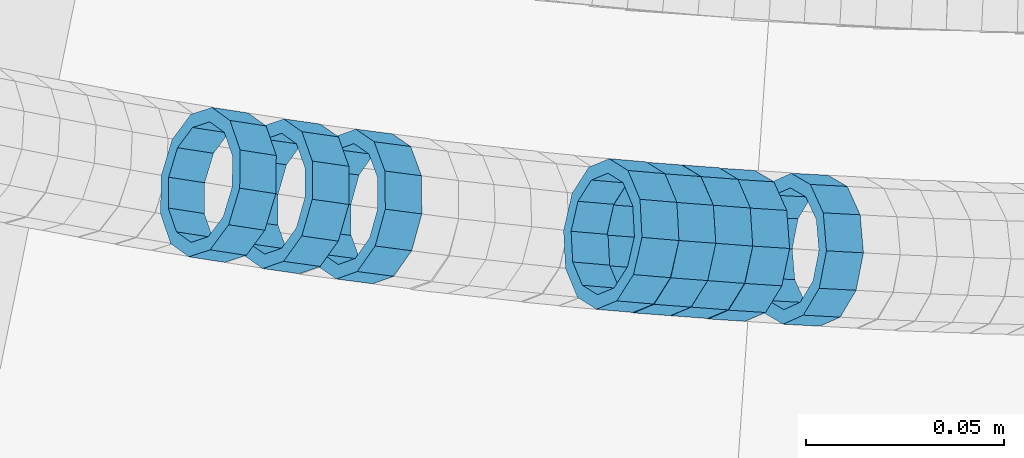
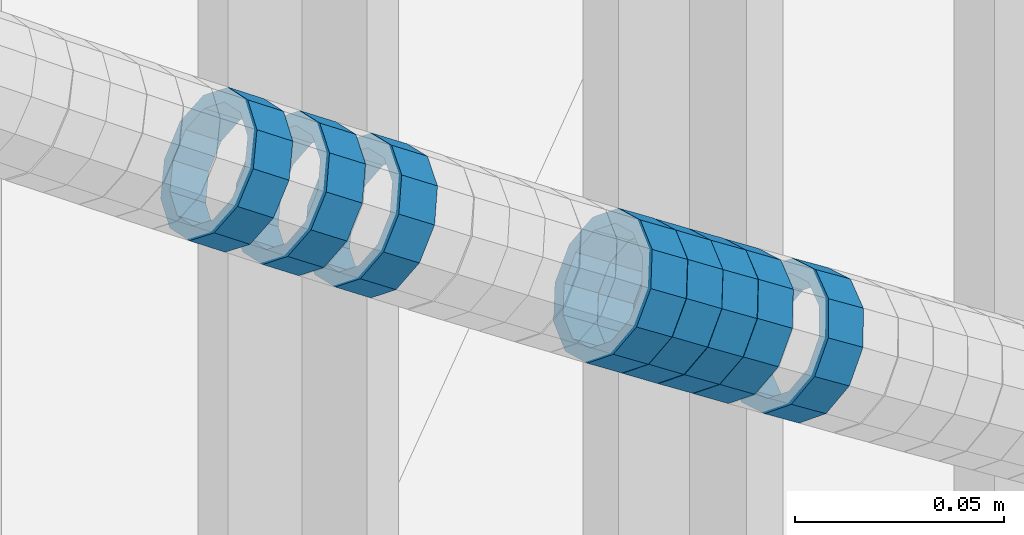
# One storey, part 684 of 975: 8 members.
"""IFC2X3 building model written with IfcOpenShell, lengths in millimetres."""

from ifc_helpers import new_model, si_unit, frame, origin_with_axes, place, context, subcontext, project, spatial, faceted_brep, material, type_object, element, save


model = new_model("IFC2X3")

# Units and contexts
model_context = context("Model", 3, precision=1e-05, world=origin_with_axes())
body_context = subcontext(model_context, "Body", "Model", "MODEL_VIEW")
ifc_project = project(units=[si_unit("LENGTHUNIT", "METRE", prefix="MILLI"), si_unit("AREAUNIT", "SQUARE_METRE"), si_unit("VOLUMEUNIT", "CUBIC_METRE"), si_unit("MASSUNIT", "GRAM", prefix="KILO"), si_unit("TIMEUNIT", "SECOND"), si_unit("PLANEANGLEUNIT", "RADIAN"), si_unit("SOLIDANGLEUNIT", "STERADIAN"), si_unit("THERMODYNAMICTEMPERATUREUNIT", "DEGREE_CELSIUS"), si_unit("LUMINOUSINTENSITYUNIT", "LUMEN")], contexts=[model_context])

# Site, building, storey
site_placement = place(None, origin_with_axes())
site = spatial("IfcSite", under=ifc_project, at=site_placement, CompositionType="ELEMENT")
building_placement = place(site_placement, origin_with_axes())
building = spatial("IfcBuilding", under=site, at=building_placement, Name="Undefined", CompositionType="ELEMENT")
storey_placement = place(building_placement, origin_with_axes())
storey = spatial("IfcBuildingStorey", under=building, at=storey_placement, Name="Undefined", CompositionType="ELEMENT", Elevation=0.0)

# Members
ifc_material = material()
member_type = type_object("IfcMemberType", PredefinedType="NOTDEFINED")
member_1_placement = place(storey_placement, frame((34649.9665897505, 1926.44126368959, 4259.15155085601), z_axis=(-0.0536859073060332, -0.998557871811508, 1.96610926650465e-10), x_axis=(-0.85170692112707, 0.0457906950068331, 0.522013920077845)))
element("IfcMember", 1, at=member_1_placement, inside=storey, type_object=member_type, material=ifc_material, Name="WALL", context=body_context, shape_type="Brep", body=[
    faceted_brep([(-2.1246523829177e-07, -15.367000000002, 0.0), (-1.83998054126278e-07, -13.3082123799541, 7.68350000000009), (10.9242848735521, -13.3082123800159, 7.68350000000919), (10.9242848735703, -15.3670000000457, 6.82121026329696e-12), (-1.06232619145885e-07, -7.68349999999919, 13.3082123799559), (10.9242848735521, -7.68350000005739, 13.3082123799652), (-3.63797880709171e-12, 3.63797880709171e-12, 15.3670000000002), (10.924284873563, -4.72937244921923e-11, 15.3670000000088), (1.06225343188271e-07, 7.68350000000646, 13.3082123799559), (10.9242848735885, 7.68349999997008, 13.308212379962), (1.8399441614747e-07, 13.308212379965, 7.68350000000009), (10.9242848736176, 13.3082123799468, 7.68350000000328), (2.12461600312963e-07, 15.3670000000093, 0.0), (10.9242848736394, 15.3670000000093, 0.0), (1.8399441614747e-07, 13.308212379965, -7.68350000000009), (10.9242848736576, 13.3082123799795, -7.6835000000026), (1.06225343188271e-07, 7.68350000000646, -13.3082123799559), (10.9242848736576, 7.68350000002465, -13.3082123799584), (-3.63797880709171e-12, 3.63797880709171e-12, -15.3670000000002), (10.9242848736467, 1.45519152283669e-11, -15.3670000000025), (-1.06232619145885e-07, -7.68349999999919, -13.3082123799559), (10.9242848736212, -7.68350000000282, -13.3082123799552), (-1.83998054126278e-07, -13.3082123799541, -7.68350000000009), (10.9242848735958, -13.3082123799832, -7.68349999999646), (-2.63386027654633e-07, -19.0500000000029, 0.0), (-2.28097633225843e-07, -16.4977839420972, -9.52499999999964), (10.9242848735885, -16.4977839421226, -9.52499999999577), (10.9242848735557, -19.0500000000575, 8.18545231595635e-12), (-1.31691194837913e-07, -9.52500000000146, -16.4977839420935), (10.9242848736249, -9.52500000000146, -16.4977839420942), (-3.63797880709171e-12, 3.63797880709171e-12, -19.0500000000002), (10.924284873654, 2.18278728425503e-11, -19.0500000000038), (1.31687556859106e-07, 9.52500000000509, -16.4977839420935), (10.9242848736758, 9.52500000003783, -16.4977839420985), (2.28097633225843e-07, 16.4977839421044, -9.52499999999964), (10.9242848736758, 16.4977839421299, -9.52500000000418), (2.63382389675826e-07, 19.0500000000138, 0.0), (10.9242848736503, 19.0500000000211, -1.36424205265939e-12), (2.28097633225843e-07, 16.4977839421044, 9.52499999999964), (10.9242848736249, 16.4977839420899, 9.52500000000259), (1.31687556859106e-07, 9.52500000000509, 16.4977839420935), (10.9242848735885, 9.52499999996508, 16.4977839421008), (-3.63797880709171e-12, 3.63797880709171e-12, 19.0500000000002), (10.9242848735594, -5.82076609134674e-11, 19.0500000000104), (-1.31691194837913e-07, -9.52500000000146, 16.4977839420935), (10.9242848735375, -9.52500000007058, 16.4977839421056), (-2.28097633225843e-07, -16.4977839420972, 9.52499999999964), (10.9242848735412, -16.4977839421626, 9.52500000001078)], [[[0, 1, 2, 3]], [[1, 4, 5, 2]], [[4, 6, 7, 5]], [[6, 8, 9, 7]], [[8, 10, 11, 9]], [[10, 12, 13, 11]], [[12, 14, 15, 13]], [[14, 16, 17, 15]], [[16, 18, 19, 17]], [[18, 20, 21, 19]], [[20, 22, 23, 21]], [[22, 0, 3, 23]], [[24, 25, 26, 27]], [[25, 28, 29, 26]], [[28, 30, 31, 29]], [[30, 32, 33, 31]], [[32, 34, 35, 33]], [[34, 36, 37, 35]], [[36, 38, 39, 37]], [[38, 40, 41, 39]], [[40, 42, 43, 41]], [[42, 44, 45, 43]], [[44, 46, 47, 45]], [[46, 24, 27, 47]], [[29, 31, 33, 35, 37, 39, 41, 43, 45, 47, 27, 26], [5, 7, 9, 11, 13, 15, 17, 19, 21, 23, 3, 2]], [[46, 44, 42, 40, 38, 36, 34, 32, 30, 28, 25, 24], [22, 20, 18, 16, 14, 12, 10, 8, 6, 4, 1, 0]]]),
])
member_2_placement = place(storey_placement, frame((34631.2517163912, 1927.65544932693, 4270.62648604053), z_axis=(-0.0643822783268261, -0.997925308947241, 2.01563125301618e-10), x_axis=(-0.847241940782439, 0.0546607699859694, 0.528387446864275)))
element("IfcMember", 2, at=member_2_placement, inside=storey, type_object=member_type, material=ifc_material, Name="WALL", context=body_context, shape_type="Brep", body=[
    faceted_brep([(-2.1246523829177e-07, -15.367000000002, 0.0), (-1.83998054126278e-07, -13.3082123799541, 7.68350000000009), (10.9799817850508, -13.3082123799686, 7.6835000000051), (10.9799817850435, -15.3670000000202, 5.45696821063757e-12), (-1.06232619145885e-07, -7.68349999999919, 13.3082123799559), (10.9799817850653, -7.68350000000282, 13.3082123799577), (-3.63797880709171e-12, 3.63797880709171e-12, 15.3670000000002), (10.9799817850871, 1.45519152283669e-11, 15.3669999999984), (1.06225343188271e-07, 7.68350000000646, 13.3082123799559), (10.9799817851053, 7.68350000002465, 13.3082123799504), (1.8399441614747e-07, 13.308212379965, 7.68350000000009), (10.9799817851163, 13.3082123799904, 7.68349999999191), (2.12461600312963e-07, 15.3670000000093, 0.0), (10.9799817851199, 15.3670000000347, -9.09494701772928e-12), (1.8399441614747e-07, 13.308212379965, -7.68350000000009), (10.9799817851126, 13.3082123799832, -7.68350000000783), (1.06225343188271e-07, 7.68350000000646, -13.3082123799559), (10.9799817850981, 7.68350000001737, -13.3082123799613), (-3.63797880709171e-12, 3.63797880709171e-12, -15.3670000000002), (10.9799817850799, 3.63797880709171e-12, -15.367000000002), (-1.06232619145885e-07, -7.68349999999919, -13.3082123799559), (10.9799817850653, -7.68350000000646, -13.308212379955), (-1.83998054126278e-07, -13.3082123799541, -7.68350000000009), (10.9799817850508, -13.3082123799722, -7.68349999999509), (-2.63386027654633e-07, -19.0500000000029, 0.0), (-2.28097633225843e-07, -16.4977839420972, -9.52499999999964), (10.9799817850399, -16.4977839421153, -9.52499999999418), (10.9799817850362, -19.0500000000247, 6.3664629124105e-12), (-1.31691194837913e-07, -9.52500000000146, -16.4977839420935), (10.979981785058, -9.52500000001237, -16.4977839420912), (-3.63797880709171e-12, 3.63797880709171e-12, -19.0500000000002), (10.9799817850799, 0.0, -19.050000000002), (1.31687556859106e-07, 9.52500000000509, -16.4977839420935), (10.9799817851017, 9.52500000001965, -16.4977839420999), (2.28097633225843e-07, 16.4977839421044, -9.52499999999964), (10.9799817851235, 16.4977839421299, -9.5250000000101), (2.63382389675826e-07, 19.0500000000138, 0.0), (10.9799817851308, 19.0500000000393, -1.09139364212751e-11), (2.28097633225843e-07, 16.4977839421044, 9.52499999999964), (10.9799817851235, 16.4977839421335, 9.52499999999054), (1.31687556859106e-07, 9.52500000000509, 16.4977839420935), (10.979981785109, 9.52500000003056, 16.4977839420881), (-3.63797880709171e-12, 3.63797880709171e-12, 19.0500000000002), (10.9799817850871, 1.45519152283669e-11, 19.0499999999984), (-1.31691194837913e-07, -9.52500000000146, 16.4977839420935), (10.9799817850617, -9.52500000000509, 16.4977839420962), (-2.28097633225843e-07, -16.4977839420972, 9.52499999999964), (10.9799817850435, -16.4977839421117, 9.52500000000691)], [[[0, 1, 2, 3]], [[1, 4, 5, 2]], [[4, 6, 7, 5]], [[6, 8, 9, 7]], [[8, 10, 11, 9]], [[10, 12, 13, 11]], [[12, 14, 15, 13]], [[14, 16, 17, 15]], [[16, 18, 19, 17]], [[18, 20, 21, 19]], [[20, 22, 23, 21]], [[22, 0, 3, 23]], [[24, 25, 26, 27]], [[25, 28, 29, 26]], [[28, 30, 31, 29]], [[30, 32, 33, 31]], [[32, 34, 35, 33]], [[34, 36, 37, 35]], [[36, 38, 39, 37]], [[38, 40, 41, 39]], [[40, 42, 43, 41]], [[42, 44, 45, 43]], [[44, 46, 47, 45]], [[46, 24, 27, 47]], [[29, 31, 33, 35, 37, 39, 41, 43, 45, 47, 27, 26], [5, 7, 9, 11, 13, 15, 17, 19, 21, 23, 3, 2]], [[46, 44, 42, 40, 38, 36, 34, 32, 30, 28, 25, 24], [22, 20, 18, 16, 14, 12, 10, 8, 6, 4, 1, 0]]]),
])
member_3_placement = place(storey_placement, frame((34622.0902642617, 1928.35303064289, 4276.34543886208), z_axis=(-0.0750565052296879, -0.997179282287145, 1.26812665257603e-10), x_axis=(-0.850851006159265, 0.0640425490119867, 0.521489326097682)))
element("IfcMember", 3, at=member_3_placement, inside=storey, type_object=member_type, material=ifc_material, Name="WALL", context=body_context, shape_type="Brep", body=[
    faceted_brep([(-2.1246523829177e-07, -15.367000000002, 0.0), (-1.83998054126278e-07, -13.3082123799541, 7.68350000000009), (10.9334349588862, -13.3082123799722, 7.68350000000555), (10.9334349588862, -15.3670000000166, 5.45696821063757e-12), (-1.06232619145885e-07, -7.68349999999919, 13.3082123799559), (10.9334349588826, -7.68350000001737, 13.3082123799609), (-3.63797880709171e-12, 3.63797880709171e-12, 15.3670000000002), (10.9334349588862, -1.45519152283669e-11, 15.3670000000043), (1.06225343188271e-07, 7.68350000000646, 13.3082123799559), (10.9334349588898, 7.68349999998827, 13.3082123799591), (1.8399441614747e-07, 13.308212379965, 7.68350000000009), (10.9334349588898, 13.3082123799395, 7.68350000000419), (2.12461600312963e-07, 15.3670000000093, 0.0), (10.9334349588971, 15.3669999999911, 3.63797880709171e-12), (1.8399441614747e-07, 13.308212379965, -7.68350000000009), (10.9334349588935, 13.3082123799431, -7.683499999996), (1.06225343188271e-07, 7.68350000000646, -13.3082123799559), (10.9334349588971, 7.68349999998827, -13.3082123799518), (-3.63797880709171e-12, 3.63797880709171e-12, -15.3670000000002), (10.9334349588971, -1.45519152283669e-11, -15.3669999999961), (-1.06232619145885e-07, -7.68349999999919, -13.3082123799559), (10.9334349588935, -7.68350000001737, -13.3082123799509), (-1.83998054126278e-07, -13.3082123799541, -7.68350000000009), (10.9334349588898, -13.3082123799686, -7.68349999999464), (-2.63386027654633e-07, -19.0500000000029, 0.0), (-2.28097633225843e-07, -16.4977839420972, -9.52499999999964), (10.9334349588898, -16.4977839421117, -9.52499999999372), (10.9334349588898, -19.0500000000211, 5.45696821063757e-12), (-1.31691194837913e-07, -9.52500000000146, -16.4977839420935), (10.9334349588971, -9.52500000001237, -16.4977839420885), (-3.63797880709171e-12, 3.63797880709171e-12, -19.0500000000002), (10.9334349588971, -1.09139364212751e-11, -19.0499999999961), (1.31687556859106e-07, 9.52500000000509, -16.4977839420935), (10.9334349589008, 9.52499999999054, -16.4977839420894), (2.28097633225843e-07, 16.4977839421044, -9.52499999999964), (10.9334349589008, 16.4977839420826, -9.52499999999645), (2.63382389675826e-07, 19.0500000000138, 0.0), (10.9334349588898, 19.0499999999884, 3.18323145620525e-12), (2.28097633225843e-07, 16.4977839421044, 9.52499999999964), (10.9334349588935, 16.497783942079, 9.52500000000282), (1.31687556859106e-07, 9.52500000000509, 16.4977839420935), (10.9334349588826, 9.52499999998327, 16.4977839420976), (-3.63797880709171e-12, 3.63797880709171e-12, 19.0500000000002), (10.9334349588826, -1.81898940354586e-11, 19.0500000000043), (-1.31691194837913e-07, -9.52500000000146, 16.4977839420935), (10.9334349588826, -9.52500000001965, 16.4977839420994), (-2.28097633225843e-07, -16.4977839420972, 9.52499999999964), (10.9334349588826, -16.4977839421117, 9.52500000000646)], [[[0, 1, 2, 3]], [[1, 4, 5, 2]], [[4, 6, 7, 5]], [[6, 8, 9, 7]], [[8, 10, 11, 9]], [[10, 12, 13, 11]], [[12, 14, 15, 13]], [[14, 16, 17, 15]], [[16, 18, 19, 17]], [[18, 20, 21, 19]], [[20, 22, 23, 21]], [[22, 0, 3, 23]], [[24, 25, 26, 27]], [[25, 28, 29, 26]], [[28, 30, 31, 29]], [[30, 32, 33, 31]], [[32, 34, 35, 33]], [[34, 36, 37, 35]], [[36, 38, 39, 37]], [[38, 40, 41, 39]], [[40, 42, 43, 41]], [[42, 44, 45, 43]], [[44, 46, 47, 45]], [[46, 24, 27, 47]], [[29, 31, 33, 35, 37, 39, 41, 43, 45, 47, 27, 26], [5, 7, 9, 11, 13, 15, 17, 19, 21, 23, 3, 2]], [[46, 44, 42, 40, 38, 36, 34, 32, 30, 28, 25, 24], [22, 20, 18, 16, 14, 12, 10, 8, 6, 4, 1, 0]]]),
])
member_4_placement = place(storey_placement, frame((34603.5050028846, 1929.8582826926, 4287.84163248184), z_axis=(-0.0857049941950463, -0.996320557837701, 1.2716009223368e-10), x_axis=(-0.850317367145023, 0.0731455800124648, 0.521162258088779)))
element("IfcMember", 4, at=member_4_placement, inside=storey, type_object=member_type, material=ifc_material, Name="WALL", context=body_context, shape_type="Brep", body=[
    faceted_brep([(-2.1246523829177e-07, -15.367000000002, 0.0), (-1.83998054126278e-07, -13.3082123799541, 7.68350000000009), (10.9448618081915, -13.3082123799541, 7.68349999999987), (10.944861808206, -15.3669999999875, -1.81898940354586e-12), (-1.06232619145885e-07, -7.68349999999919, 13.3082123799559), (10.9448618081733, -7.68350000000282, 13.3082123799568), (-3.63797880709171e-12, 3.63797880709171e-12, 15.3670000000002), (10.944861808166, -1.09139364212751e-11, 15.3670000000025), (1.06225343188271e-07, 7.68350000000646, 13.3082123799559), (10.9448618081624, 7.68349999998827, 13.3082123799586), (1.8399441614747e-07, 13.308212379965, 7.68350000000009), (10.9448618081697, 13.3082123799468, 7.68350000000214), (2.12461600312963e-07, 15.3670000000093, 0.0), (10.9448618081842, 15.3669999999984, 2.27373675443232e-13), (1.8399441614747e-07, 13.308212379965, -7.68350000000009), (10.9448618082024, 13.3082123799613, -7.68350000000123), (1.06225343188271e-07, 7.68350000000646, -13.3082123799559), (10.944861808217, 7.68350000001374, -13.3082123799586), (-3.63797880709171e-12, 3.63797880709171e-12, -15.3670000000002), (10.9448618082242, 1.45519152283669e-11, -15.3670000000036), (-1.06232619145885e-07, -7.68349999999919, -13.3082123799559), (10.9448618082279, -7.68349999997736, -13.30821237996), (-1.83998054126278e-07, -13.3082123799541, -7.68350000000009), (10.9448618082242, -13.3082123799322, -7.68350000000351), (-2.63386027654633e-07, -19.0500000000029, 0.0), (-2.28097633225843e-07, -16.4977839420972, -9.52499999999964), (10.9448618082242, -16.4977839420681, -9.52500000000418), (10.9448618082097, -19.0499999999847, -2.50111042987555e-12), (-1.31691194837913e-07, -9.52500000000146, -16.4977839420935), (10.9448618082351, -9.52499999997599, -16.4977839420985), (-3.63797880709171e-12, 3.63797880709171e-12, -19.0500000000002), (10.9448618082315, 2.5465851649642e-11, -19.050000000004), (1.31687556859106e-07, 9.52500000000509, -16.4977839420935), (10.9448618082242, 9.52500000001601, -16.4977839420967), (2.28097633225843e-07, 16.4977839421044, -9.52499999999964), (10.9448618082097, 16.4977839421008, -9.52500000000146), (2.63382389675826e-07, 19.0500000000138, 0.0), (10.9448618081842, 19.049999999992, 1.13686837721616e-12), (2.28097633225843e-07, 16.4977839421044, 9.52499999999964), (10.944861808166, 16.4977839420826, 9.52500000000259), (1.31687556859106e-07, 9.52500000000509, 16.4977839420935), (10.9448618081624, 9.52499999998327, 16.4977839420972), (-3.63797880709171e-12, 3.63797880709171e-12, 19.0500000000002), (10.9448618081587, -1.09139364212751e-11, 19.0500000000031), (-1.31691194837913e-07, -9.52500000000146, 16.4977839420935), (10.9448618081697, -9.52500000000873, 16.4977839420953), (-2.28097633225843e-07, -16.4977839420972, 9.52499999999964), (10.9448618081915, -16.4977839420899, 9.52499999999941)], [[[0, 1, 2, 3]], [[1, 4, 5, 2]], [[4, 6, 7, 5]], [[6, 8, 9, 7]], [[8, 10, 11, 9]], [[10, 12, 13, 11]], [[12, 14, 15, 13]], [[14, 16, 17, 15]], [[16, 18, 19, 17]], [[18, 20, 21, 19]], [[20, 22, 23, 21]], [[22, 0, 3, 23]], [[24, 25, 26, 27]], [[25, 28, 29, 26]], [[28, 30, 31, 29]], [[30, 32, 33, 31]], [[32, 34, 35, 33]], [[34, 36, 37, 35]], [[36, 38, 39, 37]], [[38, 40, 41, 39]], [[40, 42, 43, 41]], [[42, 44, 45, 43]], [[44, 46, 47, 45]], [[46, 24, 27, 47]], [[29, 31, 33, 35, 37, 39, 41, 43, 45, 47, 27, 26], [5, 7, 9, 11, 13, 15, 17, 19, 21, 23, 3, 2]], [[46, 44, 42, 40, 38, 36, 34, 32, 30, 28, 25, 24], [22, 20, 18, 16, 14, 12, 10, 8, 6, 4, 1, 0]]]),
])
member_5_placement = place(storey_placement, frame((34612.6646361625, 1929.06248652131, 4282.12311053159), z_axis=(-0.0750565052296879, -0.997179282287145, 1.26812665257603e-10), x_axis=(-0.846785254104728, 0.0637365240078824, 0.528102631065387)))
element("IfcMember", 5, at=member_5_placement, inside=storey, type_object=member_type, material=ifc_material, Name="WALL", context=body_context, shape_type="Brep", body=[
    faceted_brep([(-2.1246523829177e-07, -15.367000000002, 0.0), (-1.83998054126278e-07, -13.3082123799541, 7.68350000000009), (10.9799817850508, -13.3082123799686, 7.6835000000051), (10.9799817850435, -15.3670000000202, 5.45696821063757e-12), (-1.06232619145885e-07, -7.68349999999919, 13.3082123799559), (10.9799817850653, -7.68350000000282, 13.3082123799577), (-3.63797880709171e-12, 3.63797880709171e-12, 15.3670000000002), (10.9799817850871, 1.45519152283669e-11, 15.3669999999984), (1.06225343188271e-07, 7.68350000000646, 13.3082123799559), (10.9799817851053, 7.68350000002465, 13.3082123799504), (1.8399441614747e-07, 13.308212379965, 7.68350000000009), (10.9799817851163, 13.3082123799904, 7.68349999999191), (2.12461600312963e-07, 15.3670000000093, 0.0), (10.9799817851199, 15.3670000000347, -9.09494701772928e-12), (1.8399441614747e-07, 13.308212379965, -7.68350000000009), (10.9799817851126, 13.3082123799832, -7.68350000000783), (1.06225343188271e-07, 7.68350000000646, -13.3082123799559), (10.9799817850981, 7.68350000001737, -13.3082123799613), (-3.63797880709171e-12, 3.63797880709171e-12, -15.3670000000002), (10.9799817850799, 3.63797880709171e-12, -15.367000000002), (-1.06232619145885e-07, -7.68349999999919, -13.3082123799559), (10.9799817850653, -7.68350000000646, -13.308212379955), (-1.83998054126278e-07, -13.3082123799541, -7.68350000000009), (10.9799817850508, -13.3082123799722, -7.68349999999509), (-2.63386027654633e-07, -19.0500000000029, 0.0), (-2.28097633225843e-07, -16.4977839420972, -9.52499999999964), (10.9799817850399, -16.4977839421153, -9.52499999999418), (10.9799817850362, -19.0500000000247, 6.3664629124105e-12), (-1.31691194837913e-07, -9.52500000000146, -16.4977839420935), (10.979981785058, -9.52500000001237, -16.4977839420912), (-3.63797880709171e-12, 3.63797880709171e-12, -19.0500000000002), (10.9799817850799, 0.0, -19.050000000002), (1.31687556859106e-07, 9.52500000000509, -16.4977839420935), (10.9799817851017, 9.52500000001965, -16.4977839420999), (2.28097633225843e-07, 16.4977839421044, -9.52499999999964), (10.9799817851235, 16.4977839421299, -9.5250000000101), (2.63382389675826e-07, 19.0500000000138, 0.0), (10.9799817851308, 19.0500000000393, -1.09139364212751e-11), (2.28097633225843e-07, 16.4977839421044, 9.52499999999964), (10.9799817851235, 16.4977839421335, 9.52499999999054), (1.31687556859106e-07, 9.52500000000509, 16.4977839420935), (10.979981785109, 9.52500000003056, 16.4977839420881), (-3.63797880709171e-12, 3.63797880709171e-12, 19.0500000000002), (10.9799817850871, 1.45519152283669e-11, 19.0499999999984), (-1.31691194837913e-07, -9.52500000000146, 16.4977839420935), (10.9799817850617, -9.52500000000509, 16.4977839420962), (-2.28097633225843e-07, -16.4977839420972, 9.52499999999964), (10.9799817850435, -16.4977839421117, 9.52500000000691)], [[[0, 1, 2, 3]], [[1, 4, 5, 2]], [[4, 6, 7, 5]], [[6, 8, 9, 7]], [[8, 10, 11, 9]], [[10, 12, 13, 11]], [[12, 14, 15, 13]], [[14, 16, 17, 15]], [[16, 18, 19, 17]], [[18, 20, 21, 19]], [[20, 22, 23, 21]], [[22, 0, 3, 23]], [[24, 25, 26, 27]], [[25, 28, 29, 26]], [[28, 30, 31, 29]], [[30, 32, 33, 31]], [[32, 34, 35, 33]], [[34, 36, 37, 35]], [[36, 38, 39, 37]], [[38, 40, 41, 39]], [[40, 42, 43, 41]], [[42, 44, 45, 43]], [[44, 46, 47, 45]], [[46, 24, 27, 47]], [[29, 31, 33, 35, 37, 39, 41, 43, 45, 47, 27, 26], [5, 7, 9, 11, 13, 15, 17, 19, 21, 23, 3, 2]], [[46, 44, 42, 40, 38, 36, 34, 32, 30, 28, 25, 24], [22, 20, 18, 16, 14, 12, 10, 8, 6, 4, 1, 0]]]),
])
member_6_placement = place(storey_placement, frame((34538.708371019, 1936.99716223161, 4328.0684984436), z_axis=(-0.129339183764649, -0.991600411225759, -1.61313437274657e-10), x_axis=(-0.844890481631006, 0.110203105951872, 0.523464754771406)))
element("IfcMember", 6, at=member_6_placement, inside=storey, type_object=member_type, material=ifc_material, Name="WALL", context=body_context, shape_type="Brep", body=[
    faceted_brep([(-2.1246523829177e-07, -15.367000000002, 0.0), (-1.83998054126278e-07, -13.3082123799541, 7.68350000000009), (10.8908218239267, -13.3082123799468, 7.68349999999828), (10.8908218239521, -15.3669999999729, -6.3664629124105e-12), (-1.06232619145885e-07, -7.68349999999919, 13.3082123799559), (10.8908218238939, -7.6835000000101, 13.3082123799586), (-3.63797880709171e-12, 3.63797880709171e-12, 15.3670000000002), (10.8908218238757, -2.18278728425503e-11, 15.3670000000075), (1.06225343188271e-07, 7.68350000000646, 13.3082123799559), (10.8908218238612, 7.68349999996644, 13.308212379965), (1.8399441614747e-07, 13.308212379965, 7.68350000000009), (10.8908218238612, 13.308212379925, 7.68350000000919), (2.12461600312963e-07, 15.3670000000093, 0.0), (10.8908218238794, 15.3669999999802, 5.45696821063757e-12), (1.8399441614747e-07, 13.308212379965, -7.68350000000009), (10.8908218239012, 13.3082123799541, -7.68349999999828), (1.06225343188271e-07, 7.68350000000646, -13.3082123799559), (10.8908218239339, 7.68350000001737, -13.30821237996), (-3.63797880709171e-12, 3.63797880709171e-12, -15.3670000000002), (10.8908218239558, 3.27418092638254e-11, -15.3670000000075), (-1.06232619145885e-07, -7.68349999999919, -13.3082123799559), (10.890821823974, -7.68349999996281, -13.308212379965), (-1.83998054126278e-07, -13.3082123799541, -7.68350000000009), (10.8908218239667, -13.3082123799177, -7.68350000000919), (-2.63386027654633e-07, -19.0500000000029, 0.0), (-2.28097633225843e-07, -16.4977839420972, -9.52499999999964), (10.8908218239812, -16.4977839420499, -9.52500000001055), (10.8908218239594, -19.0499999999665, -7.73070496506989e-12), (-1.31691194837913e-07, -9.52500000000146, -16.4977839420935), (10.8908218239812, -9.52499999994689, -16.4977839421063), (-3.63797880709171e-12, 3.63797880709171e-12, -19.0500000000002), (10.8908218239703, 3.63797880709171e-11, -19.0500000000093), (1.31687556859106e-07, 9.52500000000509, -16.4977839420935), (10.8908218239412, 9.52500000002328, -16.4977839420981), (2.28097633225843e-07, 16.4977839421044, -9.52499999999964), (10.8908218239048, 16.4977839420899, -9.52499999999873), (2.63382389675826e-07, 19.0500000000138, 0.0), (10.8908218238685, 19.0499999999774, 6.82121026329696e-12), (2.28097633225843e-07, 16.4977839421044, 9.52499999999964), (10.8908218238539, 16.4977839420535, 9.525000000011), (1.31687556859106e-07, 9.52500000000509, 16.4977839420935), (10.8908218238466, 9.52499999996144, 16.4977839421058), (-3.63797880709171e-12, 3.63797880709171e-12, 19.0500000000002), (10.8908218238648, -3.27418092638254e-11, 19.0500000000097), (-1.31691194837913e-07, -9.52500000000146, 16.4977839420935), (10.8908218238939, -9.52500000000873, 16.4977839420972), (-2.28097633225843e-07, -16.4977839420972, 9.52499999999964), (10.8908218239267, -16.4977839420826, 9.52499999999873)], [[[0, 1, 2, 3]], [[1, 4, 5, 2]], [[4, 6, 7, 5]], [[6, 8, 9, 7]], [[8, 10, 11, 9]], [[10, 12, 13, 11]], [[12, 14, 15, 13]], [[14, 16, 17, 15]], [[16, 18, 19, 17]], [[18, 20, 21, 19]], [[20, 22, 23, 21]], [[22, 0, 3, 23]], [[24, 25, 26, 27]], [[25, 28, 29, 26]], [[28, 30, 31, 29]], [[30, 32, 33, 31]], [[32, 34, 35, 33]], [[34, 36, 37, 35]], [[36, 38, 39, 37]], [[38, 40, 41, 39]], [[40, 42, 43, 41]], [[42, 44, 45, 43]], [[44, 46, 47, 45]], [[46, 24, 27, 47]], [[29, 31, 33, 35, 37, 39, 41, 43, 45, 47, 27, 26], [5, 7, 9, 11, 13, 15, 17, 19, 21, 23, 3, 2]], [[46, 44, 42, 40, 38, 36, 34, 32, 30, 28, 25, 24], [22, 20, 18, 16, 14, 12, 10, 8, 6, 4, 1, 0]]]),
])
member_7_placement = place(storey_placement, frame((34520.3330918473, 1939.50114997162, 4339.46205466786), z_axis=(-0.139914421660542, -0.990163599922455, -1.99544047063682e-10), x_axis=(-0.844001179042153, 0.119261036005972, 0.522913774026118)))
element("IfcMember", 7, at=member_7_placement, inside=storey, type_object=member_type, material=ifc_material, Name="WALL", context=body_context, shape_type="Brep", body=[
    faceted_brep([(-2.1246523829177e-07, -15.367000000002, 0.0), (-1.83998054126278e-07, -13.3082123799541, 7.68350000000009), (10.9004587059244, -13.3082123799686, 7.68350000000282), (10.9004587059426, -15.3670000000093, 9.09494701772928e-13), (-1.06232619145885e-07, -7.68349999999919, 13.3082123799559), (10.9004587059244, -7.68350000001737, 13.3082123799586), (-3.63797880709171e-12, 3.63797880709171e-12, 15.3670000000002), (10.9004587059353, -1.45519152283669e-11, 15.3670000000029), (1.06225343188271e-07, 7.68350000000646, 13.3082123799559), (10.9004587059571, 7.68349999999555, 13.308212379955), (1.8399441614747e-07, 13.308212379965, 7.68350000000009), (10.9004587059753, 13.308212379965, 7.68349999999691), (2.12461600312963e-07, 15.3670000000093, 0.0), (10.9004587059935, 15.3670000000202, -5.45696821063757e-12), (1.8399441614747e-07, 13.308212379965, -7.68350000000009), (10.9004587060081, 13.3082123799832, -7.68350000000737), (1.06225343188271e-07, 7.68350000000646, -13.3082123799559), (10.9004587060081, 7.68350000002829, -13.3082123799632), (-3.63797880709171e-12, 3.63797880709171e-12, -15.3670000000002), (10.9004587060008, 2.91038304567337e-11, -15.3670000000075), (-1.06232619145885e-07, -7.68349999999919, -13.3082123799559), (10.900458705979, -7.683499999981, -13.3082123799595), (-1.83998054126278e-07, -13.3082123799541, -7.68350000000009), (10.9004587059608, -13.3082123799504, -7.68350000000191), (-2.63386027654633e-07, -19.0500000000029, 0.0), (-2.28097633225843e-07, -16.4977839420972, -9.52499999999964), (10.9004587059499, -16.4977839420899, -9.525000000001), (10.9004587059317, -19.0500000000102, 1.81898940354586e-12), (-1.31691194837913e-07, -9.52500000000146, -16.4977839420935), (10.9004587059826, -9.52499999997963, -16.497783942099), (-3.63797880709171e-12, 3.63797880709171e-12, -19.0500000000002), (10.9004587060008, 2.91038304567337e-11, -19.0500000000084), (1.31687556859106e-07, 9.52500000000509, -16.4977839420935), (10.900458706019, 9.52500000003783, -16.4977839421026), (2.28097633225843e-07, 16.4977839421044, -9.52499999999964), (10.900458706019, 16.4977839421263, -9.52500000000873), (2.63382389675826e-07, 19.0500000000138, 0.0), (10.9004587060044, 19.0500000000247, -6.82121026329696e-12), (2.28097633225843e-07, 16.4977839421044, 9.52499999999964), (10.9004587059826, 16.4977839421044, 9.52499999999736), (1.31687556859106e-07, 9.52500000000509, 16.4977839420935), (10.9004587059571, 9.52499999999418, 16.497783942094), (-3.63797880709171e-12, 3.63797880709171e-12, 19.0500000000002), (10.900458705928, -2.18278728425503e-11, 19.0500000000038), (-1.31691194837913e-07, -9.52500000000146, 16.4977839420935), (10.9004587059135, -9.52500000002328, 16.4977839420981), (-2.28097633225843e-07, -16.4977839420972, 9.52499999999964), (10.9004587059171, -16.4977839421153, 9.52500000000373)], [[[0, 1, 2, 3]], [[1, 4, 5, 2]], [[4, 6, 7, 5]], [[6, 8, 9, 7]], [[8, 10, 11, 9]], [[10, 12, 13, 11]], [[12, 14, 15, 13]], [[14, 16, 17, 15]], [[16, 18, 19, 17]], [[18, 20, 21, 19]], [[20, 22, 23, 21]], [[22, 0, 3, 23]], [[24, 25, 26, 27]], [[25, 28, 29, 26]], [[28, 30, 31, 29]], [[30, 32, 33, 31]], [[32, 34, 35, 33]], [[34, 36, 37, 35]], [[36, 38, 39, 37]], [[38, 40, 41, 39]], [[40, 42, 43, 41]], [[42, 44, 45, 43]], [[44, 46, 47, 45]], [[46, 24, 27, 47]], [[29, 31, 33, 35, 37, 39, 41, 43, 45, 47, 27, 26], [5, 7, 9, 11, 13, 15, 17, 19, 21, 23, 3, 2]], [[46, 44, 42, 40, 38, 36, 34, 32, 30, 28, 25, 24], [22, 20, 18, 16, 14, 12, 10, 8, 6, 4, 1, 0]]]),
])
member_8_placement = place(storey_placement, frame((34501.8856660067, 1942.33215263465, 4351.00275597838), z_axis=(-0.152057184298464, -0.988371697643767, 2.16162334254477e-10), x_axis=(-0.840362079899492, 0.129286473984563, 0.526380643937102)))
element("IfcMember", 8, at=member_8_placement, inside=storey, type_object=member_type, material=ifc_material, Name="WALL", context=body_context, shape_type="Brep", body=[
    faceted_brep([(-2.1246523829177e-07, -15.367000000002, 0.0), (-1.83998054126278e-07, -13.3082123799541, 7.68350000000009), (10.8323589305219, -13.308212379965, 7.68349999999373), (10.8323589305146, -15.3670000000129, -7.27595761418343e-12), (-1.06232619145885e-07, -7.68349999999919, 13.3082123799559), (10.8323589305437, -7.68349999999919, 13.3082123799531), (-3.63797880709171e-12, 3.63797880709171e-12, 15.3670000000002), (10.8323589305655, 7.27595761418343e-12, 15.367000000002), (1.06225343188271e-07, 7.68350000000646, 13.3082123799559), (10.8323589305764, 7.6835000000101, 13.3082123799604), (1.8399441614747e-07, 13.308212379965, 7.68350000000009), (10.8323589305837, 13.3082123799722, 7.68350000000646), (2.12461600312963e-07, 15.3670000000093, 0.0), (10.8323589305801, 15.3670000000202, 6.3664629124105e-12), (1.8399441614747e-07, 13.308212379965, -7.68350000000009), (10.8323589305692, 13.3082123799722, -7.68349999999555), (1.06225343188271e-07, 7.68350000000646, -13.3082123799559), (10.832358930551, 7.68350000000646, -13.3082123799541), (-3.63797880709171e-12, 3.63797880709171e-12, -15.3670000000002), (10.8323589305328, 0.0, -15.3670000000029), (-1.06232619145885e-07, -7.68349999999919, -13.3082123799559), (10.8323589305182, -7.68350000000646, -13.3082123799604), (-1.83998054126278e-07, -13.3082123799541, -7.68350000000009), (10.8323589305146, -13.3082123799686, -7.68350000000737), (-2.63386027654633e-07, -19.0500000000029, 0.0), (-2.28097633225843e-07, -16.4977839420972, -9.52499999999964), (10.8323589305, -16.4977839421117, -9.52500000000873), (10.832358930511, -19.0500000000102, -9.09494701772928e-12), (-1.31691194837913e-07, -9.52500000000146, -16.4977839420935), (10.8323589305146, -9.52500000000873, -16.4977839420999), (-3.63797880709171e-12, 3.63797880709171e-12, -19.0500000000002), (10.8323589305328, 3.63797880709171e-12, -19.0500000000029), (1.31687556859106e-07, 9.52500000000509, -16.4977839420935), (10.8323589305546, 9.52500000000873, -16.4977839420917), (2.28097633225843e-07, 16.4977839421044, -9.52499999999964), (10.8323589305764, 16.4977839421117, -9.52499999999327), (2.63382389675826e-07, 19.0500000000138, 0.0), (10.8323589305874, 19.0500000000211, 8.18545231595635e-12), (2.28097633225843e-07, 16.4977839421044, 9.52499999999964), (10.832358930591, 16.4977839421153, 9.52500000000873), (1.31687556859106e-07, 9.52500000000509, 16.4977839420935), (10.8323589305837, 9.52500000001601, 16.4977839420999), (-3.63797880709171e-12, 3.63797880709171e-12, 19.0500000000002), (10.8323589305619, 7.27595761418343e-12, 19.0500000000011), (-1.31691194837913e-07, -9.52500000000146, 16.4977839420935), (10.8323589305401, -9.52500000000146, 16.4977839420908), (-2.28097633225843e-07, -16.4977839420972, 9.52499999999964), (10.8323589305219, -16.4977839421044, 9.52499999999236)], [[[0, 1, 2, 3]], [[1, 4, 5, 2]], [[4, 6, 7, 5]], [[6, 8, 9, 7]], [[8, 10, 11, 9]], [[10, 12, 13, 11]], [[12, 14, 15, 13]], [[14, 16, 17, 15]], [[16, 18, 19, 17]], [[18, 20, 21, 19]], [[20, 22, 23, 21]], [[22, 0, 3, 23]], [[24, 25, 26, 27]], [[25, 28, 29, 26]], [[28, 30, 31, 29]], [[30, 32, 33, 31]], [[32, 34, 35, 33]], [[34, 36, 37, 35]], [[36, 38, 39, 37]], [[38, 40, 41, 39]], [[40, 42, 43, 41]], [[42, 44, 45, 43]], [[44, 46, 47, 45]], [[46, 24, 27, 47]], [[29, 31, 33, 35, 37, 39, 41, 43, 45, 47, 27, 26], [5, 7, 9, 11, 13, 15, 17, 19, 21, 23, 3, 2]], [[46, 44, 42, 40, 38, 36, 34, 32, 30, 28, 25, 24], [22, 20, 18, 16, 14, 12, 10, 8, 6, 4, 1, 0]]]),
])

save(model, "model.ifc")
